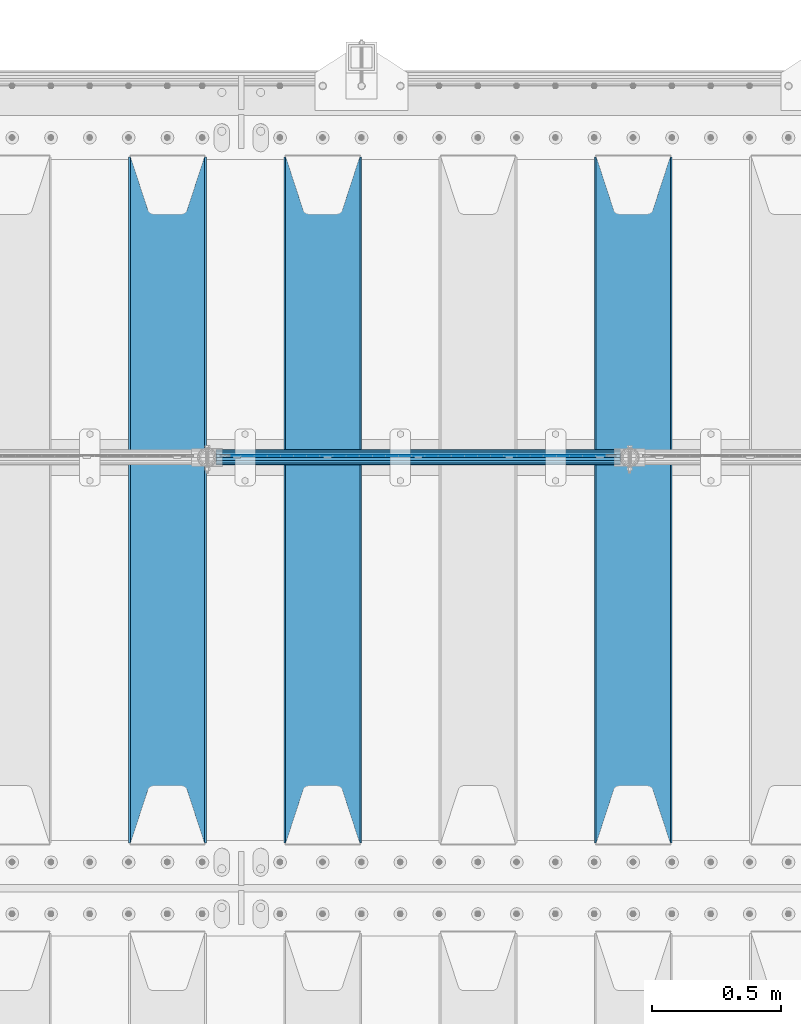
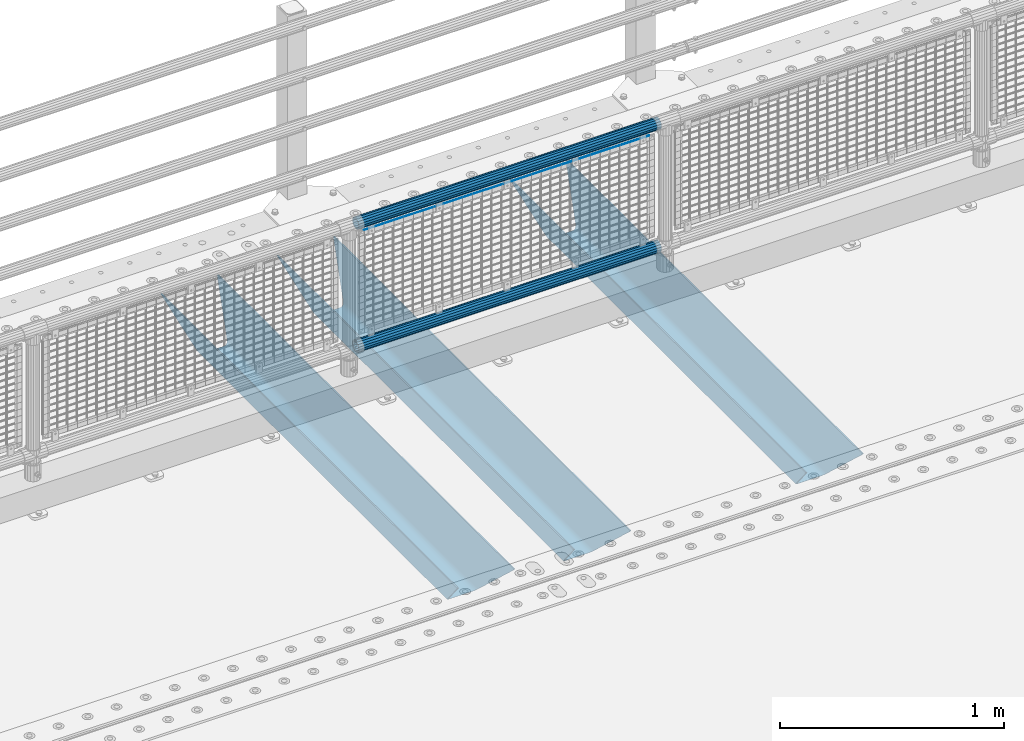
# One storey, part 122 of 242: 6 beams.
"""IFC2X3 building model written with IfcOpenShell, lengths in millimetres."""

from ifc_helpers import new_model, si_unit, frame, origin_with_axes, place, context, subcontext, project, spatial, faceted_brep, material, type_object, element, save


model = new_model("IFC2X3")

# Units and contexts
model_context = context("Model", 3, precision=1e-05, world=origin_with_axes())
body_context = subcontext(model_context, "Body", "Model", "MODEL_VIEW")
ifc_project = project(units=[si_unit("LENGTHUNIT", "METRE", prefix="MILLI"), si_unit("AREAUNIT", "SQUARE_METRE"), si_unit("VOLUMEUNIT", "CUBIC_METRE"), si_unit("MASSUNIT", "GRAM", prefix="KILO"), si_unit("TIMEUNIT", "SECOND"), si_unit("PLANEANGLEUNIT", "RADIAN"), si_unit("SOLIDANGLEUNIT", "STERADIAN"), si_unit("THERMODYNAMICTEMPERATUREUNIT", "DEGREE_CELSIUS"), si_unit("LUMINOUSINTENSITYUNIT", "LUMEN")], contexts=[model_context])

# Site, building, storey
site_placement = place(None, origin_with_axes())
site = spatial("IfcSite", under=ifc_project, at=site_placement, CompositionType="ELEMENT")
building_placement = place(site_placement, origin_with_axes())
building = spatial("IfcBuilding", under=site, at=building_placement, Name="Standard", CompositionType="ELEMENT")
storey_placement = place(building_placement, origin_with_axes())
storey = spatial("IfcBuildingStorey", under=building, at=storey_placement, Name="Undefined", CompositionType="ELEMENT", Elevation=0.0)

# Beams
ifc_material_1 = material(Name="Misc_Undefined")
beam_type_1 = type_object("IfcBeamType", Name="D3", PredefinedType="NOTDEFINED")
beam_1_placement = place(storey_placement, frame((-35217.0, -19329.5, 913.02), z_axis=(0.0, 0.0, 1.0), x_axis=(1.0, 0.0, 0.0)))
element("IfcBeam", 1, at=beam_1_placement, inside=storey, type_object=beam_type_1, material=ifc_material_1, ObjectType="D3", context=body_context, shape_type="Brep", body=[
    faceted_brep([(0.0, -1.50000000000364, 0.0), (-3.63797880709171e-12, -0.750000000003638, -1.29903810567669), (1473.0, -0.75, -1.29903810567669), (1473.0, -1.5, 0.0), (0.0, 0.749999999996362, -1.29903810567669), (1473.0, 0.75, -1.29903810567663), (-3.63797880709171e-12, 1.49999999999636, 0.0), (1473.0, 1.5, 0.0), (0.0, 0.749999999996362, 1.29903810567669), (1473.0, 0.75, 1.29903810567669), (-3.63797880709171e-12, -0.750000000003638, 1.29903810567669), (1473.0, -0.75, 1.29903810567669)], [[[0, 1, 2, 3]], [[1, 4, 5, 2]], [[4, 6, 7, 5]], [[6, 8, 9, 7]], [[8, 10, 11, 9]], [[10, 0, 3, 11]], [[5, 7, 9, 11, 3, 2]], [[10, 8, 6, 4, 1, 0]]]),
])
ifc_material_2 = material()
beam_type_2 = type_object("IfcBeamType", PredefinedType="NOTDEFINED")
beam_2_placement = place(storey_placement, frame((-35262.15, -19335.5, 969.849999999999), z_axis=(0.0, 0.0, 1.0), x_axis=(1.0, 0.0, 0.0)))
element("IfcBeam", 2, at=beam_2_placement, inside=storey, type_object=beam_type_2, material=ifc_material_2, context=body_context, shape_type="Brep", body=[
    faceted_brep([(0.0, -25.3499999999985, 0.0), (0.0, -23.4203461491597, 9.70102501045403), (1563.0, -23.4203461491597, 9.70102501045506), (1563.0, -25.3499999999985, 0.0), (0.0, -17.9251569030785, 17.9251569030785), (1563.0, -17.9251569030785, 17.925156903079), (0.0, -9.70102501045403, 23.4203461491597), (1563.0, -9.70102501045403, 23.4203461491611), (0.0, 0.0, 25.3499999999985), (1563.0, 0.0, 25.35), (0.0, 9.70102501045403, 23.4203461491597), (1563.0, 9.70102501045403, 23.4203461491611), (0.0, 17.9251569030785, 17.9251569030785), (1563.0, 17.9251569030785, 17.925156903079), (0.0, 23.4203461491597, 9.70102501045403), (1563.0, 23.4203461491597, 9.70102501045506), (0.0, 25.3499999999985, 0.0), (1563.0, 25.3499999999985, 0.0), (0.0, 23.4203461491597, -9.70102501045403), (1563.0, 23.4203461491597, -9.70102501045506), (0.0, 17.9251569030785, -17.9251569030785), (1563.0, 17.9251569030785, -17.925156903079), (0.0, 9.70102501045403, -23.4203461491597), (1563.0, 9.70102501045403, -23.4203461491611), (0.0, 0.0, -25.3499999999985), (1563.0, 0.0, -25.35), (0.0, -9.70102501045403, -23.4203461491597), (1563.0, -9.70102501045403, -23.4203461491611), (0.0, -17.9251569030785, -17.9251569030785), (1563.0, -17.9251569030785, -17.925156903079), (0.0, -23.4203461491597, -9.70102501045403), (1563.0, -23.4203461491597, -9.70102501045506), (0.0, -30.1500000000015, 0.0), (0.0, -27.8549679052157, -11.5379054858058), (1563.0, -27.8549679052157, -11.5379054858075), (1563.0, -30.1500000000015, 0.0), (0.0, -21.3192694527752, -21.3192694527752), (1563.0, -21.3192694527752, -21.3192694527744), (0.0, -11.5379054858058, -27.8549679052157), (1563.0, -11.5379054858058, -27.8549679052153), (0.0, 0.0, -30.1500000000015), (1563.0, 0.0, -30.15), (0.0, 11.5379054858058, -27.8549679052157), (1563.0, 11.5379054858058, -27.8549679052153), (0.0, 21.3192694527752, -21.3192694527752), (1563.0, 21.3192694527752, -21.3192694527744), (0.0, 27.8549679052157, -11.5379054858058), (1563.0, 27.8549679052157, -11.5379054858074), (0.0, 30.1500000000015, 0.0), (1563.0, 30.1500000000015, 0.0), (0.0, 27.8549679052157, 11.5379054858058), (1563.0, 27.8549679052157, 11.5379054858074), (0.0, 21.3192694527752, 21.3192694527752), (1563.0, 21.3192694527752, 21.3192694527744), (0.0, 11.5379054858058, 27.8549679052157), (1563.0, 11.5379054858058, 27.8549679052153), (0.0, 0.0, 30.1500000000015), (1563.0, 0.0, 30.15), (0.0, -11.5379054858058, 27.8549679052157), (1563.0, -11.5379054858058, 27.8549679052153), (0.0, -21.3192694527752, 21.3192694527752), (1563.0, -21.3192694527752, 21.3192694527744), (0.0, -27.8549679052157, 11.5379054858058), (1563.0, -27.8549679052157, 11.5379054858074)], [[[0, 1, 2, 3]], [[1, 4, 5, 2]], [[4, 6, 7, 5]], [[6, 8, 9, 7]], [[8, 10, 11, 9]], [[10, 12, 13, 11]], [[12, 14, 15, 13]], [[14, 16, 17, 15]], [[16, 18, 19, 17]], [[18, 20, 21, 19]], [[20, 22, 23, 21]], [[22, 24, 25, 23]], [[24, 26, 27, 25]], [[26, 28, 29, 27]], [[28, 30, 31, 29]], [[30, 0, 3, 31]], [[32, 33, 34, 35]], [[33, 36, 37, 34]], [[36, 38, 39, 37]], [[38, 40, 41, 39]], [[40, 42, 43, 41]], [[42, 44, 45, 43]], [[44, 46, 47, 45]], [[46, 48, 49, 47]], [[48, 50, 51, 49]], [[50, 52, 53, 51]], [[52, 54, 55, 53]], [[54, 56, 57, 55]], [[56, 58, 59, 57]], [[58, 60, 61, 59]], [[60, 62, 63, 61]], [[62, 32, 35, 63]], [[37, 39, 41, 43, 45, 47, 49, 51, 53, 55, 57, 59, 61, 63, 35, 34], [5, 7, 9, 11, 13, 15, 17, 19, 21, 23, 25, 27, 29, 31, 3, 2]], [[62, 60, 58, 56, 54, 52, 50, 48, 46, 44, 42, 40, 38, 36, 33, 32], [30, 28, 26, 24, 22, 20, 18, 16, 14, 12, 10, 8, 6, 4, 1, 0]]]),
])
beam_3_placement = place(storey_placement, frame((-35262.15, -19335.5, 298.170000000001), z_axis=(0.0, 0.0, 1.0), x_axis=(1.0, 0.0, 0.0)))
element("IfcBeam", 3, at=beam_3_placement, inside=storey, type_object=beam_type_2, material=ifc_material_2, context=body_context, shape_type="Brep", body=[
    faceted_brep([(0.0, -25.3499999999985, 0.0), (0.0, -23.4203461491597, 9.70102501045403), (1563.0, -23.4203461491597, 9.70102501045506), (1563.0, -25.3499999999985, 0.0), (0.0, -17.9251569030785, 17.9251569030785), (1563.0, -17.9251569030785, 17.925156903079), (0.0, -9.70102501045403, 23.4203461491597), (1563.0, -9.70102501045403, 23.4203461491611), (0.0, 0.0, 25.3499999999985), (1563.0, 0.0, 25.35), (0.0, 9.70102501045403, 23.4203461491597), (1563.0, 9.70102501045403, 23.4203461491611), (0.0, 17.9251569030785, 17.9251569030785), (1563.0, 17.9251569030785, 17.925156903079), (0.0, 23.4203461491597, 9.70102501045403), (1563.0, 23.4203461491597, 9.70102501045506), (0.0, 25.3499999999985, 0.0), (1563.0, 25.3499999999985, 0.0), (0.0, 23.4203461491597, -9.70102501045403), (1563.0, 23.4203461491597, -9.70102501045506), (0.0, 17.9251569030785, -17.9251569030785), (1563.0, 17.9251569030785, -17.925156903079), (0.0, 9.70102501045403, -23.4203461491597), (1563.0, 9.70102501045403, -23.4203461491611), (0.0, 0.0, -25.3499999999985), (1563.0, 0.0, -25.35), (0.0, -9.70102501045403, -23.4203461491597), (1563.0, -9.70102501045403, -23.4203461491611), (0.0, -17.9251569030785, -17.9251569030785), (1563.0, -17.9251569030785, -17.925156903079), (0.0, -23.4203461491597, -9.70102501045403), (1563.0, -23.4203461491597, -9.70102501045506), (0.0, -30.1500000000015, 0.0), (0.0, -27.8549679052157, -11.5379054858058), (1563.0, -27.8549679052157, -11.5379054858075), (1563.0, -30.1500000000015, 0.0), (0.0, -21.3192694527752, -21.3192694527752), (1563.0, -21.3192694527752, -21.3192694527744), (0.0, -11.5379054858058, -27.8549679052157), (1563.0, -11.5379054858058, -27.8549679052153), (0.0, 0.0, -30.1500000000015), (1563.0, 0.0, -30.15), (0.0, 11.5379054858058, -27.8549679052157), (1563.0, 11.5379054858058, -27.8549679052153), (0.0, 21.3192694527752, -21.3192694527752), (1563.0, 21.3192694527752, -21.3192694527744), (0.0, 27.8549679052157, -11.5379054858058), (1563.0, 27.8549679052157, -11.5379054858074), (0.0, 30.1500000000015, 0.0), (1563.0, 30.1500000000015, 0.0), (0.0, 27.8549679052157, 11.5379054858058), (1563.0, 27.8549679052157, 11.5379054858074), (0.0, 21.3192694527752, 21.3192694527752), (1563.0, 21.3192694527752, 21.3192694527744), (0.0, 11.5379054858058, 27.8549679052157), (1563.0, 11.5379054858058, 27.8549679052153), (0.0, 0.0, 30.1500000000015), (1563.0, 0.0, 30.15), (0.0, -11.5379054858058, 27.8549679052157), (1563.0, -11.5379054858058, 27.8549679052153), (0.0, -21.3192694527752, 21.3192694527752), (1563.0, -21.3192694527752, 21.3192694527744), (0.0, -27.8549679052157, 11.5379054858058), (1563.0, -27.8549679052157, 11.5379054858074)], [[[0, 1, 2, 3]], [[1, 4, 5, 2]], [[4, 6, 7, 5]], [[6, 8, 9, 7]], [[8, 10, 11, 9]], [[10, 12, 13, 11]], [[12, 14, 15, 13]], [[14, 16, 17, 15]], [[16, 18, 19, 17]], [[18, 20, 21, 19]], [[20, 22, 23, 21]], [[22, 24, 25, 23]], [[24, 26, 27, 25]], [[26, 28, 29, 27]], [[28, 30, 31, 29]], [[30, 0, 3, 31]], [[32, 33, 34, 35]], [[33, 36, 37, 34]], [[36, 38, 39, 37]], [[38, 40, 41, 39]], [[40, 42, 43, 41]], [[42, 44, 45, 43]], [[44, 46, 47, 45]], [[46, 48, 49, 47]], [[48, 50, 51, 49]], [[50, 52, 53, 51]], [[52, 54, 55, 53]], [[54, 56, 57, 55]], [[56, 58, 59, 57]], [[58, 60, 61, 59]], [[60, 62, 63, 61]], [[62, 32, 35, 63]], [[37, 39, 41, 43, 45, 47, 49, 51, 53, 55, 57, 59, 61, 63, 35, 34], [5, 7, 9, 11, 13, 15, 17, 19, 21, 23, 25, 27, 29, 31, 3, 2]], [[62, 60, 58, 56, 54, 52, 50, 48, 46, 44, 42, 40, 38, 36, 33, 32], [30, 28, 26, 24, 22, 20, 18, 16, 14, 12, 10, 8, 6, 4, 1, 0]]]),
])
ifc_material_3 = material(Name="STEEL/S355N")
beam_type_3 = type_object("IfcBeamType", PredefinedType="NOTDEFINED")
beam_4_placement = place(storey_placement, frame((-33650.0, -20825.0, -115.0), z_axis=(0.0, 0.0, 1.0), x_axis=(0.0, 1.0, 0.0)))
element("IfcBeam", 4, at=beam_4_placement, inside=storey, type_object=beam_type_3, material=ifc_material_3, context=body_context, shape_type="Brep", body=[
    faceted_brep([(0.0, 150.0, 115.0), (0.0, 143.689999999999, 115.0), (2650.00000000297, 143.689999999999, 115.0), (2650.00000000297, 150.0, 115.0), (2650.00000000297, 142.059565218402, 110.000000003099), (2650.00000000297, 148.369565218403, 110.000000003099), (2441.90079219209, -80.1103600731112, -98.0992078077845), (2437.7588105432, -77.5672621345584, -102.241189456673), (2434.06523489747, -74.4080125315522, -105.934765102404), (2430.91086095089, -70.710272125576, -109.089139048974), (2428.37322971128, -66.5649389910068, -111.626770288588), (2426.51472138055, -62.0739139532889, -113.485278619323), (2425.38102192092, -57.3475956567672, -114.618978078955), (2424.99999999987, -52.5021667386536, -115.0), (2424.99999999987, 52.5021667386536, -115.0), (2425.38102192092, 57.3475956567672, -114.618978078955), (2426.51472138055, 62.0739139532889, -113.485278619323), (2428.37322971128, 66.5649389910068, -111.626770288588), (2430.91086095089, 70.710272125576, -109.089139048974), (2434.06523489747, 74.4080125315522, -105.934765102404), (2437.7588105432, 77.5672621345584, -102.241189456673), (2441.90079219209, 80.1103600731112, -98.0992078077846), (2446.38936140511, 81.9747917625791, -93.6106385947584), (2448.2494850041, 76.2713538057251, -91.7505149957729), (2444.62967112262, 74.76777986261, -95.3703288772456), (2441.28936334126, 72.7168944282894, -98.710636658607), (2438.31067330438, 70.1691124903846, -101.689326695487), (2435.76682334747, 67.1870637758839, -104.233176652398), (2433.72034654133, 63.8440531834895, -106.279653458539), (2432.22154950042, 60.222258798236, -107.778450499454), (2431.30727574265, 56.4107117849089, -108.692724257221), (2430.99999999987, 52.5031078186876, -109.0), (2430.99999999987, -52.5031078186876, -109.0), (2431.30727574265, -56.4107117849089, -108.692724257221), (2432.22154950042, -60.222258798236, -107.778450499454), (2433.72034654133, -63.8440531834895, -106.279653458539), (2435.76682334747, -67.1870637758839, -104.233176652398), (2438.31067330438, -70.1691124903846, -101.689326695487), (2441.28936334126, -72.7168944282894, -98.7106366586071), (2444.62967112262, -74.76777986261, -95.3703288772457), (2448.2494850041, -76.2713538057251, -91.7505149957729), (2650.00000000297, -142.059565218402, 110.000000003099), (2650.00000000297, -148.369565218403, 110.000000003099), (2446.38936140511, -81.9747917625791, -93.6106385947584), (2650.00000000297, -143.689999999999, 115.0), (2650.00000000297, -150.0, 115.0), (0.0, -143.689999999999, 115.0), (0.0, -150.0, 115.0), (0.0, -148.369565218261, 110.000000002669), (203.610638597427, -81.9747917625791, -93.6106385947584), (208.099207810454, -80.1103600731112, -98.0992078077845), (212.241189459342, -77.5672621345584, -102.241189456673), (215.934765105074, -74.4080125315522, -105.934765102404), (219.089139051644, -70.710272125576, -109.089139048974), (221.626770291256, -66.5649389910068, -111.626770288588), (223.485278621993, -62.0739139532889, -113.485278619323), (224.618978081624, -57.3475956567672, -114.618978078955), (225.00000000267, -52.5021667386536, -115.0), (225.00000000267, 52.5021667386536, -115.0), (224.618978081624, 57.3475956567672, -114.618978078955), (223.485278621993, 62.0739139532889, -113.485278619323), (221.626770291256, 66.5649389910068, -111.626770288588), (219.089139051644, 70.710272125576, -109.089139048974), (215.934765105074, 74.4080125315522, -105.934765102404), (212.241189459342, 77.5672621345584, -102.241189456673), (208.099207810454, 80.1103600731112, -98.0992078077846), (203.610638597427, 81.9747917625791, -93.6106385947584), (0.0, 148.369565218261, 110.000000002669), (0.0, 142.05956521826, 110.000000002669), (201.750514998443, 76.2713538057251, -91.7505149957729), (205.370328879915, 74.76777986261, -95.3703288772456), (208.710636661275, 72.7168944282894, -98.710636658607), (211.689326698157, 70.1691124903846, -101.689326695487), (214.233176655067, 67.1870637758839, -104.233176652398), (216.279653461206, 63.8440531834895, -106.279653458539), (217.778450502123, 60.222258798236, -107.778450499454), (218.69272425989, 56.4107117849089, -108.692724257221), (219.00000000267, 52.5031078186876, -109.0), (219.00000000267, -52.5031078186876, -109.0), (218.69272425989, -56.4107117849089, -108.692724257221), (217.778450502123, -60.222258798236, -107.778450499454), (216.279653461206, -63.8440531834895, -106.279653458539), (214.233176655067, -67.1870637758839, -104.233176652398), (211.689326698157, -70.1691124903846, -101.689326695487), (208.710636661275, -72.7168944282894, -98.7106366586071), (205.370328879915, -74.76777986261, -95.3703288772457), (201.750514998443, -76.2713538057251, -91.7505149957729), (0.0, -142.05956521826, 110.000000002669)], [[[0, 1, 2, 3]], [[3, 2, 4, 5]], [[6, 7, 8, 9, 10, 11, 12, 13, 14, 15, 16, 17, 18, 19, 20, 21, 22, 5, 4, 23, 24, 25, 26, 27, 28, 29, 30, 31, 32, 33, 34, 35, 36, 37, 38, 39, 40, 41, 42, 43]], [[44, 45, 42, 41]], [[46, 47, 45, 44]], [[43, 42, 45, 47, 48, 49]], [[6, 43, 49, 50]], [[7, 6, 50, 51]], [[8, 7, 51, 52]], [[9, 8, 52, 53]], [[10, 9, 53, 54]], [[11, 10, 54, 55]], [[12, 11, 55, 56]], [[13, 12, 56, 57]], [[14, 13, 57, 58]], [[15, 14, 58, 59]], [[16, 15, 59, 60]], [[17, 16, 60, 61]], [[18, 17, 61, 62]], [[19, 18, 62, 63]], [[20, 19, 63, 64]], [[21, 20, 64, 65]], [[22, 21, 65, 66]], [[0, 3, 5, 22, 66, 67]], [[1, 0, 67, 68]], [[23, 4, 2, 1, 68, 69]], [[24, 23, 69, 70]], [[25, 24, 70, 71]], [[26, 25, 71, 72]], [[27, 26, 72, 73]], [[28, 27, 73, 74]], [[29, 28, 74, 75]], [[30, 29, 75, 76]], [[31, 30, 76, 77]], [[32, 31, 77, 78]], [[33, 32, 78, 79]], [[34, 33, 79, 80]], [[35, 34, 80, 81]], [[36, 35, 81, 82]], [[37, 36, 82, 83]], [[38, 37, 83, 84]], [[39, 38, 84, 85]], [[40, 39, 85, 86]], [[46, 44, 41, 40, 86, 87]], [[47, 46, 87, 48]], [[86, 85, 84, 83, 82, 81, 80, 79, 78, 77, 76, 75, 74, 73, 72, 71, 70, 69, 68, 67, 66, 65, 64, 63, 62, 61, 60, 59, 58, 57, 56, 55, 54, 53, 52, 51, 50, 49, 48, 87]]]),
])
beam_5_placement = place(storey_placement, frame((-34850.0, -20825.0, -115.0), z_axis=(0.0, 0.0, 1.0), x_axis=(0.0, 1.0, 0.0)))
element("IfcBeam", 5, at=beam_5_placement, inside=storey, type_object=beam_type_3, material=ifc_material_3, context=body_context, shape_type="Brep", body=[
    faceted_brep([(0.0, 150.0, 115.0), (0.0, 143.689999999999, 115.0), (2650.00000000297, 143.689999999999, 115.0), (2650.00000000297, 150.0, 115.0), (2650.00000000297, 142.059565218402, 110.000000003099), (2650.00000000297, 148.369565218403, 110.000000003099), (2441.90079219209, -80.1103600731112, -98.0992078077845), (2437.7588105432, -77.5672621345584, -102.241189456673), (2434.06523489747, -74.4080125315522, -105.934765102404), (2430.91086095089, -70.710272125576, -109.089139048974), (2428.37322971128, -66.5649389910068, -111.626770288588), (2426.51472138055, -62.0739139532889, -113.485278619323), (2425.38102192092, -57.3475956567672, -114.618978078955), (2424.99999999987, -52.5021667386536, -115.0), (2424.99999999987, 52.5021667386536, -115.0), (2425.38102192092, 57.3475956567672, -114.618978078955), (2426.51472138055, 62.0739139532889, -113.485278619323), (2428.37322971128, 66.5649389910068, -111.626770288588), (2430.91086095089, 70.710272125576, -109.089139048974), (2434.06523489747, 74.4080125315522, -105.934765102404), (2437.7588105432, 77.5672621345584, -102.241189456673), (2441.90079219209, 80.1103600731112, -98.0992078077846), (2446.38936140511, 81.9747917625791, -93.6106385947584), (2448.2494850041, 76.2713538057251, -91.7505149957729), (2444.62967112262, 74.76777986261, -95.3703288772456), (2441.28936334126, 72.7168944282894, -98.710636658607), (2438.31067330438, 70.1691124903846, -101.689326695487), (2435.76682334747, 67.1870637758839, -104.233176652398), (2433.72034654133, 63.8440531834895, -106.279653458539), (2432.22154950042, 60.222258798236, -107.778450499454), (2431.30727574265, 56.4107117849089, -108.692724257221), (2430.99999999987, 52.5031078186876, -109.0), (2430.99999999987, -52.5031078186876, -109.0), (2431.30727574265, -56.4107117849089, -108.692724257221), (2432.22154950042, -60.222258798236, -107.778450499454), (2433.72034654133, -63.8440531834895, -106.279653458539), (2435.76682334747, -67.1870637758839, -104.233176652398), (2438.31067330438, -70.1691124903846, -101.689326695487), (2441.28936334126, -72.7168944282894, -98.7106366586071), (2444.62967112262, -74.76777986261, -95.3703288772457), (2448.2494850041, -76.2713538057251, -91.7505149957729), (2650.00000000297, -142.059565218402, 110.000000003099), (2650.00000000297, -148.369565218403, 110.000000003099), (2446.38936140511, -81.9747917625791, -93.6106385947584), (2650.00000000297, -143.689999999999, 115.0), (2650.00000000297, -150.0, 115.0), (0.0, -143.689999999999, 115.0), (0.0, -150.0, 115.0), (0.0, -148.369565218261, 110.000000002669), (203.610638597427, -81.9747917625791, -93.6106385947584), (208.099207810454, -80.1103600731112, -98.0992078077845), (212.241189459342, -77.5672621345584, -102.241189456673), (215.934765105074, -74.4080125315522, -105.934765102404), (219.089139051644, -70.710272125576, -109.089139048974), (221.626770291256, -66.5649389910068, -111.626770288588), (223.485278621993, -62.0739139532889, -113.485278619323), (224.618978081624, -57.3475956567672, -114.618978078955), (225.00000000267, -52.5021667386536, -115.0), (225.00000000267, 52.5021667386536, -115.0), (224.618978081624, 57.3475956567672, -114.618978078955), (223.485278621993, 62.0739139532889, -113.485278619323), (221.626770291256, 66.5649389910068, -111.626770288588), (219.089139051644, 70.710272125576, -109.089139048974), (215.934765105074, 74.4080125315522, -105.934765102404), (212.241189459342, 77.5672621345584, -102.241189456673), (208.099207810454, 80.1103600731112, -98.0992078077846), (203.610638597427, 81.9747917625791, -93.6106385947584), (0.0, 148.369565218261, 110.000000002669), (0.0, 142.05956521826, 110.000000002669), (201.750514998443, 76.2713538057251, -91.7505149957729), (205.370328879915, 74.76777986261, -95.3703288772456), (208.710636661275, 72.7168944282894, -98.710636658607), (211.689326698157, 70.1691124903846, -101.689326695487), (214.233176655067, 67.1870637758839, -104.233176652398), (216.279653461206, 63.8440531834895, -106.279653458539), (217.778450502123, 60.222258798236, -107.778450499454), (218.69272425989, 56.4107117849089, -108.692724257221), (219.00000000267, 52.5031078186876, -109.0), (219.00000000267, -52.5031078186876, -109.0), (218.69272425989, -56.4107117849089, -108.692724257221), (217.778450502123, -60.222258798236, -107.778450499454), (216.279653461206, -63.8440531834895, -106.279653458539), (214.233176655067, -67.1870637758839, -104.233176652398), (211.689326698157, -70.1691124903846, -101.689326695487), (208.710636661275, -72.7168944282894, -98.7106366586071), (205.370328879915, -74.76777986261, -95.3703288772457), (201.750514998443, -76.2713538057251, -91.7505149957729), (0.0, -142.05956521826, 110.000000002669)], [[[0, 1, 2, 3]], [[3, 2, 4, 5]], [[6, 7, 8, 9, 10, 11, 12, 13, 14, 15, 16, 17, 18, 19, 20, 21, 22, 5, 4, 23, 24, 25, 26, 27, 28, 29, 30, 31, 32, 33, 34, 35, 36, 37, 38, 39, 40, 41, 42, 43]], [[44, 45, 42, 41]], [[46, 47, 45, 44]], [[43, 42, 45, 47, 48, 49]], [[6, 43, 49, 50]], [[7, 6, 50, 51]], [[8, 7, 51, 52]], [[9, 8, 52, 53]], [[10, 9, 53, 54]], [[11, 10, 54, 55]], [[12, 11, 55, 56]], [[13, 12, 56, 57]], [[14, 13, 57, 58]], [[15, 14, 58, 59]], [[16, 15, 59, 60]], [[17, 16, 60, 61]], [[18, 17, 61, 62]], [[19, 18, 62, 63]], [[20, 19, 63, 64]], [[21, 20, 64, 65]], [[22, 21, 65, 66]], [[0, 3, 5, 22, 66, 67]], [[1, 0, 67, 68]], [[23, 4, 2, 1, 68, 69]], [[24, 23, 69, 70]], [[25, 24, 70, 71]], [[26, 25, 71, 72]], [[27, 26, 72, 73]], [[28, 27, 73, 74]], [[29, 28, 74, 75]], [[30, 29, 75, 76]], [[31, 30, 76, 77]], [[32, 31, 77, 78]], [[33, 32, 78, 79]], [[34, 33, 79, 80]], [[35, 34, 80, 81]], [[36, 35, 81, 82]], [[37, 36, 82, 83]], [[38, 37, 83, 84]], [[39, 38, 84, 85]], [[40, 39, 85, 86]], [[46, 44, 41, 40, 86, 87]], [[47, 46, 87, 48]], [[86, 85, 84, 83, 82, 81, 80, 79, 78, 77, 76, 75, 74, 73, 72, 71, 70, 69, 68, 67, 66, 65, 64, 63, 62, 61, 60, 59, 58, 57, 56, 55, 54, 53, 52, 51, 50, 49, 48, 87]]]),
])
beam_6_placement = place(storey_placement, frame((-35450.0, -20825.0, -115.0), z_axis=(0.0, 0.0, 1.0), x_axis=(0.0, 1.0, 0.0)))
element("IfcBeam", 6, at=beam_6_placement, inside=storey, type_object=beam_type_3, material=ifc_material_3, context=body_context, shape_type="Brep", body=[
    faceted_brep([(0.0, 150.0, 115.0), (0.0, 143.689999999999, 115.0), (2650.00000000297, 143.689999999999, 115.0), (2650.00000000297, 150.0, 115.0), (2650.00000000297, 142.059565218402, 110.000000003099), (2650.00000000297, 148.369565218403, 110.000000003099), (2441.90079219209, -80.1103600731112, -98.0992078077845), (2437.7588105432, -77.5672621345584, -102.241189456673), (2434.06523489747, -74.4080125315522, -105.934765102404), (2430.91086095089, -70.710272125576, -109.089139048974), (2428.37322971128, -66.5649389910068, -111.626770288588), (2426.51472138055, -62.0739139532889, -113.485278619323), (2425.38102192092, -57.3475956567672, -114.618978078955), (2424.99999999987, -52.5021667386536, -115.0), (2424.99999999987, 52.5021667386536, -115.0), (2425.38102192092, 57.3475956567672, -114.618978078955), (2426.51472138055, 62.0739139532889, -113.485278619323), (2428.37322971128, 66.5649389910068, -111.626770288588), (2430.91086095089, 70.710272125576, -109.089139048974), (2434.06523489747, 74.4080125315522, -105.934765102404), (2437.7588105432, 77.5672621345584, -102.241189456673), (2441.90079219209, 80.1103600731112, -98.0992078077846), (2446.38936140511, 81.9747917625791, -93.6106385947584), (2448.2494850041, 76.2713538057251, -91.7505149957729), (2444.62967112262, 74.76777986261, -95.3703288772456), (2441.28936334126, 72.7168944282894, -98.710636658607), (2438.31067330438, 70.1691124903846, -101.689326695487), (2435.76682334747, 67.1870637758839, -104.233176652398), (2433.72034654133, 63.8440531834895, -106.279653458539), (2432.22154950042, 60.222258798236, -107.778450499454), (2431.30727574265, 56.4107117849089, -108.692724257221), (2430.99999999987, 52.5031078186876, -109.0), (2430.99999999987, -52.5031078186876, -109.0), (2431.30727574265, -56.4107117849089, -108.692724257221), (2432.22154950042, -60.222258798236, -107.778450499454), (2433.72034654133, -63.8440531834895, -106.279653458539), (2435.76682334747, -67.1870637758839, -104.233176652398), (2438.31067330438, -70.1691124903846, -101.689326695487), (2441.28936334126, -72.7168944282894, -98.7106366586071), (2444.62967112262, -74.76777986261, -95.3703288772457), (2448.2494850041, -76.2713538057251, -91.7505149957729), (2650.00000000297, -142.059565218402, 110.000000003099), (2650.00000000297, -148.369565218403, 110.000000003099), (2446.38936140511, -81.9747917625791, -93.6106385947584), (2650.00000000297, -143.689999999999, 115.0), (2650.00000000297, -150.0, 115.0), (0.0, -143.689999999999, 115.0), (0.0, -150.0, 115.0), (0.0, -148.369565218261, 110.000000002669), (203.610638597427, -81.9747917625791, -93.6106385947584), (208.099207810454, -80.1103600731112, -98.0992078077845), (212.241189459342, -77.5672621345584, -102.241189456673), (215.934765105074, -74.4080125315522, -105.934765102404), (219.089139051644, -70.710272125576, -109.089139048974), (221.626770291256, -66.5649389910068, -111.626770288588), (223.485278621993, -62.0739139532889, -113.485278619323), (224.618978081624, -57.3475956567672, -114.618978078955), (225.00000000267, -52.5021667386536, -115.0), (225.00000000267, 52.5021667386536, -115.0), (224.618978081624, 57.3475956567672, -114.618978078955), (223.485278621993, 62.0739139532889, -113.485278619323), (221.626770291256, 66.5649389910068, -111.626770288588), (219.089139051644, 70.710272125576, -109.089139048974), (215.934765105074, 74.4080125315522, -105.934765102404), (212.241189459342, 77.5672621345584, -102.241189456673), (208.099207810454, 80.1103600731112, -98.0992078077846), (203.610638597427, 81.9747917625791, -93.6106385947584), (0.0, 148.369565218261, 110.000000002669), (0.0, 142.05956521826, 110.000000002669), (201.750514998443, 76.2713538057251, -91.7505149957729), (205.370328879915, 74.76777986261, -95.3703288772456), (208.710636661275, 72.7168944282894, -98.710636658607), (211.689326698157, 70.1691124903846, -101.689326695487), (214.233176655067, 67.1870637758839, -104.233176652398), (216.279653461206, 63.8440531834895, -106.279653458539), (217.778450502123, 60.222258798236, -107.778450499454), (218.69272425989, 56.4107117849089, -108.692724257221), (219.00000000267, 52.5031078186876, -109.0), (219.00000000267, -52.5031078186876, -109.0), (218.69272425989, -56.4107117849089, -108.692724257221), (217.778450502123, -60.222258798236, -107.778450499454), (216.279653461206, -63.8440531834895, -106.279653458539), (214.233176655067, -67.1870637758839, -104.233176652398), (211.689326698157, -70.1691124903846, -101.689326695487), (208.710636661275, -72.7168944282894, -98.7106366586071), (205.370328879915, -74.76777986261, -95.3703288772457), (201.750514998443, -76.2713538057251, -91.7505149957729), (0.0, -142.05956521826, 110.000000002669)], [[[0, 1, 2, 3]], [[3, 2, 4, 5]], [[6, 7, 8, 9, 10, 11, 12, 13, 14, 15, 16, 17, 18, 19, 20, 21, 22, 5, 4, 23, 24, 25, 26, 27, 28, 29, 30, 31, 32, 33, 34, 35, 36, 37, 38, 39, 40, 41, 42, 43]], [[44, 45, 42, 41]], [[46, 47, 45, 44]], [[43, 42, 45, 47, 48, 49]], [[6, 43, 49, 50]], [[7, 6, 50, 51]], [[8, 7, 51, 52]], [[9, 8, 52, 53]], [[10, 9, 53, 54]], [[11, 10, 54, 55]], [[12, 11, 55, 56]], [[13, 12, 56, 57]], [[14, 13, 57, 58]], [[15, 14, 58, 59]], [[16, 15, 59, 60]], [[17, 16, 60, 61]], [[18, 17, 61, 62]], [[19, 18, 62, 63]], [[20, 19, 63, 64]], [[21, 20, 64, 65]], [[22, 21, 65, 66]], [[0, 3, 5, 22, 66, 67]], [[1, 0, 67, 68]], [[23, 4, 2, 1, 68, 69]], [[24, 23, 69, 70]], [[25, 24, 70, 71]], [[26, 25, 71, 72]], [[27, 26, 72, 73]], [[28, 27, 73, 74]], [[29, 28, 74, 75]], [[30, 29, 75, 76]], [[31, 30, 76, 77]], [[32, 31, 77, 78]], [[33, 32, 78, 79]], [[34, 33, 79, 80]], [[35, 34, 80, 81]], [[36, 35, 81, 82]], [[37, 36, 82, 83]], [[38, 37, 83, 84]], [[39, 38, 84, 85]], [[40, 39, 85, 86]], [[46, 44, 41, 40, 86, 87]], [[47, 46, 87, 48]], [[86, 85, 84, 83, 82, 81, 80, 79, 78, 77, 76, 75, 74, 73, 72, 71, 70, 69, 68, 67, 66, 65, 64, 63, 62, 61, 60, 59, 58, 57, 56, 55, 54, 53, 52, 51, 50, 49, 48, 87]]]),
])

save(model, "model.ifc")
